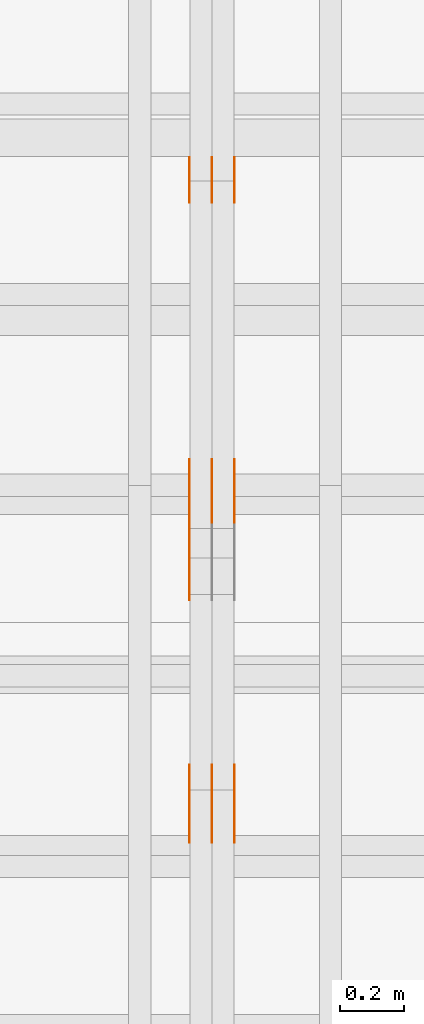
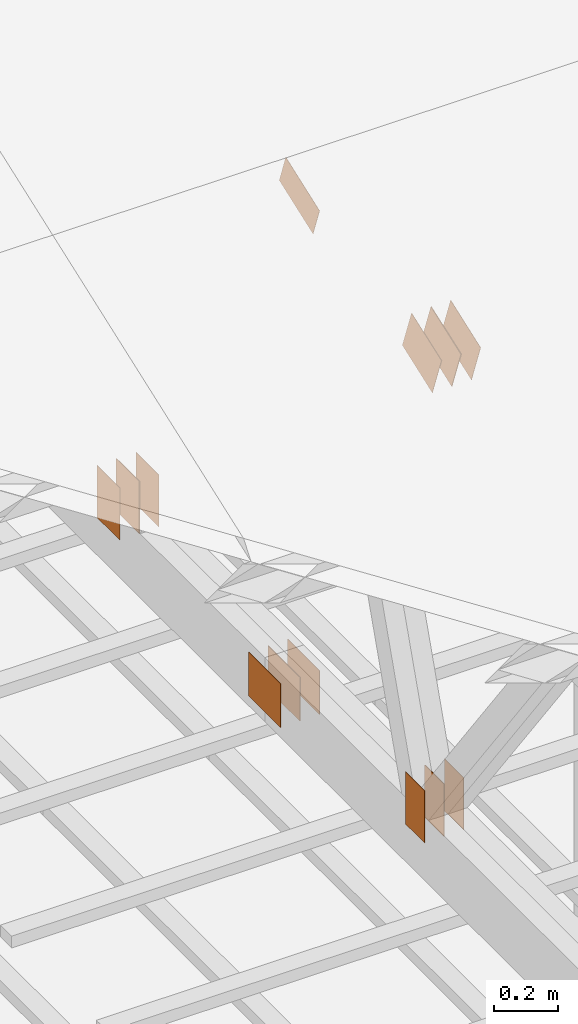
# One storey, part 144 of 189: 17 proxies.
"""IFC2X3 building model written with IfcOpenShell, lengths in millimetres."""

from ifc_helpers import new_model, entity, si_unit, converted_unit, derived_unit, direction, frame, frame_2d, origin, origin_2d_with_axis, place, context, subcontext, project, spatial, polyline, rectangle, outline, extrude, source, transform, mapped, material, type_object, type_shapes, element, save


model = new_model("IFC2X3")

# Units and contexts
model_context = context("Model", 3, precision=0.01, world=origin(), true_north=direction((6.12303176911189e-17, 1.0)))
body_context = subcontext(model_context, "Body", "Model", "MODEL_VIEW")
ifc_project = project(units=[si_unit("LENGTHUNIT", "METRE", prefix="MILLI"), si_unit("AREAUNIT", "SQUARE_METRE"), si_unit("VOLUMEUNIT", "CUBIC_METRE"), converted_unit("PLANEANGLEUNIT", "DEGREE", entity("IfcRatioMeasure", 0.0174532925199433), si_unit("PLANEANGLEUNIT", "RADIAN"), dimensions=[0, 0, 0, 0, 0, 0, 0]), si_unit("MASSUNIT", "GRAM", prefix="KILO"), derived_unit("MASSDENSITYUNIT", [(si_unit("MASSUNIT", "GRAM", prefix="KILO"), 1), (si_unit("LENGTHUNIT", "METRE"), -3)]), si_unit("TIMEUNIT", "SECOND"), si_unit("FREQUENCYUNIT", "HERTZ"), si_unit("THERMODYNAMICTEMPERATUREUNIT", "DEGREE_CELSIUS"), derived_unit("THERMALTRANSMITTANCEUNIT", [(si_unit("MASSUNIT", "GRAM", prefix="KILO"), 1), (si_unit("THERMODYNAMICTEMPERATUREUNIT", "KELVIN"), -1), (si_unit("TIMEUNIT", "SECOND"), -3)]), derived_unit("VOLUMETRICFLOWRATEUNIT", [(si_unit("LENGTHUNIT", "METRE"), 3), (si_unit("TIMEUNIT", "SECOND"), -1)]), si_unit("ELECTRICCURRENTUNIT", "AMPERE"), si_unit("ELECTRICVOLTAGEUNIT", "VOLT"), si_unit("POWERUNIT", "WATT"), si_unit("FORCEUNIT", "NEWTON"), si_unit("ILLUMINANCEUNIT", "LUX"), si_unit("LUMINOUSFLUXUNIT", "LUMEN"), si_unit("LUMINOUSINTENSITYUNIT", "CANDELA"), derived_unit("USERDEFINED", [(si_unit("MASSUNIT", "GRAM", prefix="KILO"), -1), (si_unit("LENGTHUNIT", "METRE"), -2), (si_unit("TIMEUNIT", "SECOND"), 3), (si_unit("LUMINOUSFLUXUNIT", "LUMEN"), 1)]), derived_unit("LINEARVELOCITYUNIT", [(si_unit("LENGTHUNIT", "METRE"), 1), (si_unit("TIMEUNIT", "SECOND"), -1)]), si_unit("PRESSUREUNIT", "PASCAL"), derived_unit("USERDEFINED", [(si_unit("LENGTHUNIT", "METRE"), -2), (si_unit("MASSUNIT", "GRAM", prefix="KILO"), 1), (si_unit("TIMEUNIT", "SECOND"), -2)])], contexts=[model_context])

# Site, building, storey
site_placement = place(None, origin())
site = spatial("IfcSite", under=ifc_project, at=site_placement, CompositionType="ELEMENT")
building_placement = place(site_placement, origin())
building = spatial("IfcBuilding", under=site, at=building_placement, CompositionType="ELEMENT")
storey_placement = place(building_placement, origin())
storey = spatial("IfcBuildingStorey", under=building, at=storey_placement, Name="Default", CompositionType="ELEMENT", Elevation=0.0)

# Proxies
ifc_material_1 = material(Name="IfcSurfaceStyle #252692")
building_element_proxy_type_1 = type_object("IfcBuildingElementProxyType", PredefinedType="NOTDEFINED", material=ifc_material_1)
shared_shape_1 = source(origin(), body_context, "Body", "SweptSolid", [
    extrude(rectangle(XDim=200.0, YDim=144.0, at=frame_2d((1.4210854715202e-14, 0.0), x_axis=(1.0, 0.0))), frame((100.0, 72.0, 0.0), z_axis=(0.0, 0.0, 1.0), x_axis=(-1.0, 0.0, 0.0)), (0.0, 0.0, 1.0), 1.3),
])
type_shapes(building_element_proxy_type_1, [shared_shape_1])
proxy_1_placement = place(building_placement, frame((45301.3, 6668.833984375, 145.0), z_axis=(-1.0, 0.0, 0.0), x_axis=(0.0, 0.0, 1.0)))
element("IfcBuildingElementProxy", 1, at=proxy_1_placement, inside=storey, type_object=building_element_proxy_type_1, material=ifc_material_1, context=body_context, shape_type="MappedRepresentation", body=[
    mapped(shared_shape_1, transform((0.0, 0.0, 0.0), scale=1.0)),
])
ifc_material_2 = material(Name="IfcSurfaceStyle #252635")
building_element_proxy_type_2 = type_object("IfcBuildingElementProxyType", PredefinedType="NOTDEFINED", material=ifc_material_2)
shared_shape_2 = source(origin(), body_context, "Body", "SweptSolid", [
    extrude(rectangle(XDim=200.0, YDim=144.0, at=frame_2d((1.4210854715202e-14, 0.0), x_axis=(1.0, 0.0))), frame((100.0, 72.0, 0.0), z_axis=(0.0, 0.0, 1.0), x_axis=(-1.0, 0.0, 0.0)), (0.0, 0.0, 1.0), 1.29999999999998),
])
type_shapes(building_element_proxy_type_2, [shared_shape_2])
proxy_2_placement = place(building_placement, frame((45230.0, 6668.833984375, 145.0), z_axis=(-1.0, 0.0, 0.0), x_axis=(0.0, 0.0, 1.0)))
element("IfcBuildingElementProxy", 2, at=proxy_2_placement, inside=storey, type_object=building_element_proxy_type_2, material=ifc_material_2, context=body_context, shape_type="MappedRepresentation", body=[
    mapped(shared_shape_2, transform((0.0, 0.0, 0.0), scale=1.0)),
])
ifc_material_3 = material(Name="IfcSurfaceStyle #252578")
building_element_proxy_type_3 = type_object("IfcBuildingElementProxyType", PredefinedType="NOTDEFINED", material=ifc_material_3)
shared_shape_3 = source(origin(), body_context, "Body", "SweptSolid", [
    extrude(rectangle(XDim=200.0, YDim=144.0, at=frame_2d((1.4210854715202e-14, 0.0), x_axis=(1.0, 0.0))), frame((100.0, 72.0, 0.0), z_axis=(0.0, 0.0, 1.0), x_axis=(-1.0, 0.0, 0.0)), (0.0, 0.0, 1.0), 1.29999999999998),
])
type_shapes(building_element_proxy_type_3, [shared_shape_3])
proxy_3_placement = place(building_placement, frame((45231.3, 6668.833984375, 145.0), z_axis=(-1.0, 0.0, 0.0), x_axis=(0.0, 0.0, 1.0)))
element("IfcBuildingElementProxy", 3, at=proxy_3_placement, inside=storey, type_object=building_element_proxy_type_3, material=ifc_material_3, context=body_context, shape_type="MappedRepresentation", body=[
    mapped(shared_shape_3, transform((0.0, 0.0, 0.0), scale=1.0)),
])
ifc_material_4 = material(Name="IfcSurfaceStyle #252521")
building_element_proxy_type_4 = type_object("IfcBuildingElementProxyType", PredefinedType="NOTDEFINED", material=ifc_material_4)
shared_shape_4 = source(origin(), body_context, "Body", "SweptSolid", [
    extrude(rectangle(XDim=200.0, YDim=144.0, at=frame_2d((1.4210854715202e-14, 0.0), x_axis=(1.0, 0.0))), frame((100.0, 72.0, 0.0), z_axis=(0.0, 0.0, 1.0), x_axis=(-1.0, 0.0, 0.0)), (0.0, 0.0, 1.0), 1.29999999999999),
])
type_shapes(building_element_proxy_type_4, [shared_shape_4])
proxy_4_placement = place(building_placement, frame((45160.0, 6668.833984375, 145.0), z_axis=(-1.0, 0.0, 0.0), x_axis=(0.0, 0.0, 1.0)))
element("IfcBuildingElementProxy", 4, at=proxy_4_placement, inside=storey, type_object=building_element_proxy_type_4, material=ifc_material_4, context=body_context, shape_type="MappedRepresentation", body=[
    mapped(shared_shape_4, transform((0.0, 0.0, 0.0), scale=1.0)),
])
ifc_material_5 = material(Name="IfcSurfaceStyle #252464")
building_element_proxy_type_5 = type_object("IfcBuildingElementProxyType", PredefinedType="NOTDEFINED", material=ifc_material_5)
shared_shape_5 = source(origin(), body_context, "Body", "SweptSolid", [
    extrude(rectangle(XDim=200.0, YDim=168.0, at=origin_2d_with_axis()), frame((100.0, 84.0, 0.0), z_axis=(0.0, 0.0, 1.0), x_axis=(-1.0, 0.0, 0.0)), (0.0, 0.0, 1.0), 1.3),
])
type_shapes(building_element_proxy_type_5, [shared_shape_5])
proxy_5_placement = place(building_placement, frame((45301.3, 5662.466796875, 206.5), z_axis=(-1.0, 0.0, 0.0), x_axis=(0.0, 1.0, 0.0)))
element("IfcBuildingElementProxy", 5, at=proxy_5_placement, inside=storey, type_object=building_element_proxy_type_5, material=ifc_material_5, context=body_context, shape_type="MappedRepresentation", body=[
    mapped(shared_shape_5, transform((0.0, 0.0, 0.0), scale=1.0)),
])
ifc_material_6 = material(Name="IfcSurfaceStyle #252407")
building_element_proxy_type_6 = type_object("IfcBuildingElementProxyType", PredefinedType="NOTDEFINED", material=ifc_material_6)
shared_shape_6 = source(origin(), body_context, "Body", "SweptSolid", [
    extrude(rectangle(XDim=200.0, YDim=168.0, at=origin_2d_with_axis()), frame((100.0, 84.0, 0.0), z_axis=(0.0, 0.0, 1.0), x_axis=(-1.0, 0.0, 0.0)), (0.0, 0.0, 1.0), 1.29999999999998),
])
type_shapes(building_element_proxy_type_6, [shared_shape_6])
proxy_6_placement = place(building_placement, frame((45230.0, 5662.466796875, 206.5), z_axis=(-1.0, 0.0, 0.0), x_axis=(0.0, 1.0, 0.0)))
element("IfcBuildingElementProxy", 6, at=proxy_6_placement, inside=storey, type_object=building_element_proxy_type_6, material=ifc_material_6, context=body_context, shape_type="MappedRepresentation", body=[
    mapped(shared_shape_6, transform((0.0, 0.0, 0.0), scale=1.0)),
])
ifc_material_7 = material(Name="IfcSurfaceStyle #252350")
building_element_proxy_type_7 = type_object("IfcBuildingElementProxyType", PredefinedType="NOTDEFINED", material=ifc_material_7)
shared_shape_7 = source(origin(), body_context, "Body", "SweptSolid", [
    extrude(rectangle(XDim=200.0, YDim=168.0, at=origin_2d_with_axis()), frame((100.0, 84.0, 0.0), z_axis=(0.0, 0.0, 1.0), x_axis=(-1.0, 0.0, 0.0)), (0.0, 0.0, 1.0), 1.29999999999998),
])
type_shapes(building_element_proxy_type_7, [shared_shape_7])
proxy_7_placement = place(building_placement, frame((45231.3, 5662.466796875, 206.5), z_axis=(-1.0, 0.0, 0.0), x_axis=(0.0, 1.0, 0.0)))
element("IfcBuildingElementProxy", 7, at=proxy_7_placement, inside=storey, type_object=building_element_proxy_type_7, material=ifc_material_7, context=body_context, shape_type="MappedRepresentation", body=[
    mapped(shared_shape_7, transform((0.0, 0.0, 0.0), scale=1.0)),
])
ifc_material_8 = material(Name="IfcSurfaceStyle #252293")
building_element_proxy_type_8 = type_object("IfcBuildingElementProxyType", PredefinedType="NOTDEFINED", material=ifc_material_8)
shared_shape_8 = source(origin(), body_context, "Body", "SweptSolid", [
    extrude(rectangle(XDim=200.0, YDim=168.0, at=origin_2d_with_axis()), frame((100.0, 84.0, 0.0), z_axis=(0.0, 0.0, 1.0), x_axis=(-1.0, 0.0, 0.0)), (0.0, 0.0, 1.0), 1.29999999999999),
])
type_shapes(building_element_proxy_type_8, [shared_shape_8])
proxy_8_placement = place(building_placement, frame((45160.0, 5662.466796875, 206.5), z_axis=(-1.0, 0.0, 0.0), x_axis=(0.0, 1.0, 0.0)))
element("IfcBuildingElementProxy", 8, at=proxy_8_placement, inside=storey, type_object=building_element_proxy_type_8, material=ifc_material_8, context=body_context, shape_type="MappedRepresentation", body=[
    mapped(shared_shape_8, transform((0.0, 0.0, 0.0), scale=1.0)),
])
ifc_material_9 = material(Name="IfcSurfaceStyle #248645")
building_element_proxy_type_9 = type_object("IfcBuildingElementProxyType", PredefinedType="NOTDEFINED", material=ifc_material_9)
shared_shape_9 = source(origin(), body_context, "Body", "SweptSolid", [
    extrude(outline(polyline([(-112.500654374667, -59.9999021691247), (112.500117969231, -59.9999021691247), (112.500612624162, 59.9999021691247), (-112.500076218726, 59.9999021691247), (-112.500654374667, -59.9999021691247)])), frame((112.500612624162, 60.0003514046321, 0.0), z_axis=(0.0, 0.0, 1.0), x_axis=(-1.0, 0.0, 0.0)), (0.0, 0.0, 1.0), 1.29999999999999),
])
type_shapes(building_element_proxy_type_9, [shared_shape_9])
proxy_9_placement = place(building_placement, frame((45160.0, 5418.0703125, 2162.37353515625), z_axis=(-1.0, 0.0, 0.0), x_axis=(0.0, 0.939692620785908, 0.342020143325669)))
element("IfcBuildingElementProxy", 9, at=proxy_9_placement, inside=storey, type_object=building_element_proxy_type_9, material=ifc_material_9, context=body_context, shape_type="MappedRepresentation", body=[
    mapped(shared_shape_9, transform((0.0, 0.0, 0.0), scale=1.0)),
])
ifc_material_10 = material(Name="IfcSurfaceStyle #248132")
building_element_proxy_type_10 = type_object("IfcBuildingElementProxyType", PredefinedType="NOTDEFINED", material=ifc_material_10)
shared_shape_10 = source(origin(), body_context, "Body", "SweptSolid", [
    extrude(rectangle(XDim=200.0, YDim=120.0, at=origin_2d_with_axis()), frame((100.0, 60.0, 0.0), z_axis=(0.0, 0.0, 1.0), x_axis=(-1.0, 0.0, 0.0)), (0.0, 0.0, 1.0), 1.3),
])
type_shapes(building_element_proxy_type_10, [shared_shape_10])
proxy_10_placement = place(building_placement, frame((45301.3, 4760.65625, 145.0), z_axis=(-1.0, 0.0, 0.0), x_axis=(0.0, 0.0, 1.0)))
element("IfcBuildingElementProxy", 10, at=proxy_10_placement, inside=storey, type_object=building_element_proxy_type_10, material=ifc_material_10, context=body_context, shape_type="MappedRepresentation", body=[
    mapped(shared_shape_10, transform((0.0, 0.0, 0.0), scale=1.0)),
])
ifc_material_11 = material(Name="IfcSurfaceStyle #248075")
building_element_proxy_type_11 = type_object("IfcBuildingElementProxyType", PredefinedType="NOTDEFINED", material=ifc_material_11)
shared_shape_11 = source(origin(), body_context, "Body", "SweptSolid", [
    extrude(rectangle(XDim=200.0, YDim=120.0, at=origin_2d_with_axis()), frame((100.0, 60.0, 0.0), z_axis=(0.0, 0.0, 1.0), x_axis=(-1.0, 0.0, 0.0)), (0.0, 0.0, 1.0), 1.29999999999998),
])
type_shapes(building_element_proxy_type_11, [shared_shape_11])
proxy_11_placement = place(building_placement, frame((45230.0, 4760.65625, 145.0), z_axis=(-1.0, 0.0, 0.0), x_axis=(0.0, 0.0, 1.0)))
element("IfcBuildingElementProxy", 11, at=proxy_11_placement, inside=storey, type_object=building_element_proxy_type_11, material=ifc_material_11, context=body_context, shape_type="MappedRepresentation", body=[
    mapped(shared_shape_11, transform((0.0, 0.0, 0.0), scale=1.0)),
])
ifc_material_12 = material(Name="IfcSurfaceStyle #248018")
building_element_proxy_type_12 = type_object("IfcBuildingElementProxyType", PredefinedType="NOTDEFINED", material=ifc_material_12)
shared_shape_12 = source(origin(), body_context, "Body", "SweptSolid", [
    extrude(rectangle(XDim=200.0, YDim=120.0, at=origin_2d_with_axis()), frame((100.0, 60.0, 0.0), z_axis=(0.0, 0.0, 1.0), x_axis=(-1.0, 0.0, 0.0)), (0.0, 0.0, 1.0), 1.29999999999998),
])
type_shapes(building_element_proxy_type_12, [shared_shape_12])
proxy_12_placement = place(building_placement, frame((45231.3, 4760.65625, 145.0), z_axis=(-1.0, 0.0, 0.0), x_axis=(0.0, 0.0, 1.0)))
element("IfcBuildingElementProxy", 12, at=proxy_12_placement, inside=storey, type_object=building_element_proxy_type_12, material=ifc_material_12, context=body_context, shape_type="MappedRepresentation", body=[
    mapped(shared_shape_12, transform((0.0, 0.0, 0.0), scale=1.0)),
])
ifc_material_13 = material(Name="IfcSurfaceStyle #247961")
building_element_proxy_type_13 = type_object("IfcBuildingElementProxyType", PredefinedType="NOTDEFINED", material=ifc_material_13)
shared_shape_13 = source(origin(), body_context, "Body", "SweptSolid", [
    extrude(rectangle(XDim=200.0, YDim=120.0, at=origin_2d_with_axis()), frame((100.0, 60.0, 0.0), z_axis=(0.0, 0.0, 1.0), x_axis=(-1.0, 0.0, 0.0)), (0.0, 0.0, 1.0), 1.29999999999999),
])
type_shapes(building_element_proxy_type_13, [shared_shape_13])
proxy_13_placement = place(building_placement, frame((45160.0, 4760.65625, 145.0), z_axis=(-1.0, 0.0, 0.0), x_axis=(0.0, 0.0, 1.0)))
element("IfcBuildingElementProxy", 13, at=proxy_13_placement, inside=storey, type_object=building_element_proxy_type_13, material=ifc_material_13, context=body_context, shape_type="MappedRepresentation", body=[
    mapped(shared_shape_13, transform((0.0, 0.0, 0.0), scale=1.0)),
])
ifc_material_14 = material(Name="IfcSurfaceStyle #243236")
building_element_proxy_type_14 = type_object("IfcBuildingElementProxyType", PredefinedType="NOTDEFINED", material=ifc_material_14)
shared_shape_14 = source(origin(), body_context, "Body", "SweptSolid", [
    extrude(outline(polyline([(-99.9993269270171, -84.0000832532405), (99.9997189122032, -84.0000832532405), (99.9992851765118, 84.0000832532405), (-99.999677161698, 84.0000832532405), (-99.9993269270171, -84.0000832532405)])), frame((99.9999283659736, 84.0000832532405, 0.0), z_axis=(0.0, 0.0, 1.0), x_axis=(-1.0, 0.0, 0.0)), (0.0, 0.0, 1.0), 1.3),
])
type_shapes(building_element_proxy_type_14, [shared_shape_14])
proxy_14_placement = place(building_placement, frame((45301.3, 4654.06379965055, 2052.96988554922), z_axis=(-1.0, 0.0, 0.0), x_axis=(0.0, 0.939692620785908, 0.342020143325669)))
element("IfcBuildingElementProxy", 14, at=proxy_14_placement, inside=storey, type_object=building_element_proxy_type_14, material=ifc_material_14, context=body_context, shape_type="MappedRepresentation", body=[
    mapped(shared_shape_14, transform((0.0, 0.0, 0.0), scale=1.0)),
])
ifc_material_15 = material(Name="IfcSurfaceStyle #243179")
building_element_proxy_type_15 = type_object("IfcBuildingElementProxyType", PredefinedType="NOTDEFINED", material=ifc_material_15)
shared_shape_15 = source(origin(), body_context, "Body", "SweptSolid", [
    extrude(outline(polyline([(-99.9993269270171, -84.0000832532405), (99.9997189122032, -84.0000832532405), (99.9992851765118, 84.0000832532405), (-99.999677161698, 84.0000832532405), (-99.9993269270171, -84.0000832532405)])), frame((99.9999283659736, 84.0000832532405, 0.0), z_axis=(0.0, 0.0, 1.0), x_axis=(-1.0, 0.0, 0.0)), (0.0, 0.0, 1.0), 1.29999999999998),
])
type_shapes(building_element_proxy_type_15, [shared_shape_15])
proxy_15_placement = place(building_placement, frame((45230.0, 4654.06379965055, 2052.96988554922), z_axis=(-1.0, 0.0, 0.0), x_axis=(0.0, 0.939692620785908, 0.342020143325669)))
element("IfcBuildingElementProxy", 15, at=proxy_15_placement, inside=storey, type_object=building_element_proxy_type_15, material=ifc_material_15, context=body_context, shape_type="MappedRepresentation", body=[
    mapped(shared_shape_15, transform((0.0, 0.0, 0.0), scale=1.0)),
])
ifc_material_16 = material(Name="IfcSurfaceStyle #243122")
building_element_proxy_type_16 = type_object("IfcBuildingElementProxyType", PredefinedType="NOTDEFINED", material=ifc_material_16)
shared_shape_16 = source(origin(), body_context, "Body", "SweptSolid", [
    extrude(outline(polyline([(-99.9993269270171, -84.0000832532405), (99.9997189122032, -84.0000832532405), (99.9992851765118, 84.0000832532405), (-99.999677161698, 84.0000832532405), (-99.9993269270171, -84.0000832532405)])), frame((99.9999283659736, 84.0000832532405, 0.0), z_axis=(0.0, 0.0, 1.0), x_axis=(-1.0, 0.0, 0.0)), (0.0, 0.0, 1.0), 1.29999999999998),
])
type_shapes(building_element_proxy_type_16, [shared_shape_16])
proxy_16_placement = place(building_placement, frame((45231.3, 4654.06379965055, 2052.96988554922), z_axis=(-1.0, 0.0, 0.0), x_axis=(0.0, 0.939692620785908, 0.342020143325669)))
element("IfcBuildingElementProxy", 16, at=proxy_16_placement, inside=storey, type_object=building_element_proxy_type_16, material=ifc_material_16, context=body_context, shape_type="MappedRepresentation", body=[
    mapped(shared_shape_16, transform((0.0, 0.0, 0.0), scale=1.0)),
])
ifc_material_17 = material(Name="IfcSurfaceStyle #243065")
building_element_proxy_type_17 = type_object("IfcBuildingElementProxyType", PredefinedType="NOTDEFINED", material=ifc_material_17)
shared_shape_17 = source(origin(), body_context, "Body", "SweptSolid", [
    extrude(outline(polyline([(-99.9993269270171, -84.0000832532405), (99.9997189122032, -84.0000832532405), (99.9992851765118, 84.0000832532405), (-99.999677161698, 84.0000832532405), (-99.9993269270171, -84.0000832532405)])), frame((99.9999283659736, 84.0000832532405, 0.0), z_axis=(0.0, 0.0, 1.0), x_axis=(-1.0, 0.0, 0.0)), (0.0, 0.0, 1.0), 1.29999999999999),
])
type_shapes(building_element_proxy_type_17, [shared_shape_17])
proxy_17_placement = place(building_placement, frame((45160.0, 4654.06379965055, 2052.96988554922), z_axis=(-1.0, 0.0, 0.0), x_axis=(0.0, 0.939692620785908, 0.342020143325669)))
element("IfcBuildingElementProxy", 17, at=proxy_17_placement, inside=storey, type_object=building_element_proxy_type_17, material=ifc_material_17, context=body_context, shape_type="MappedRepresentation", body=[
    mapped(shared_shape_17, transform((0.0, 0.0, 0.0), scale=1.0)),
])

save(model, "model.ifc")
